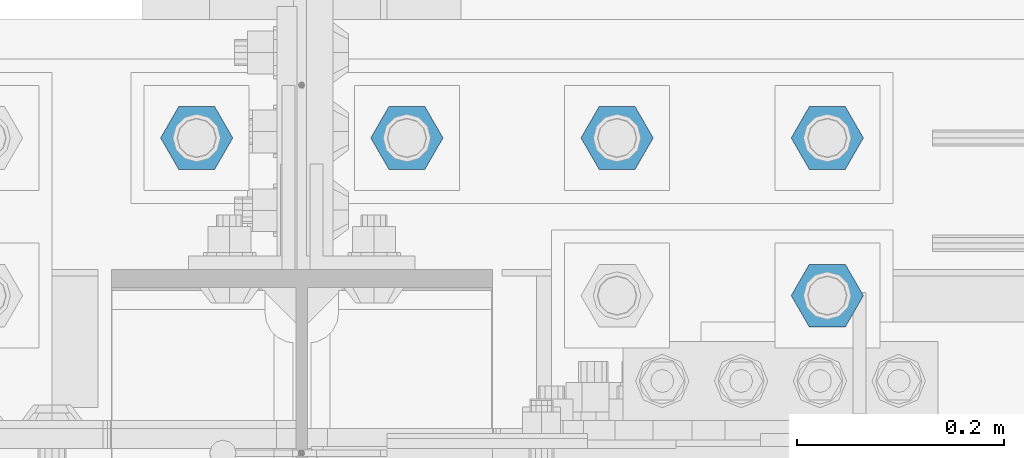
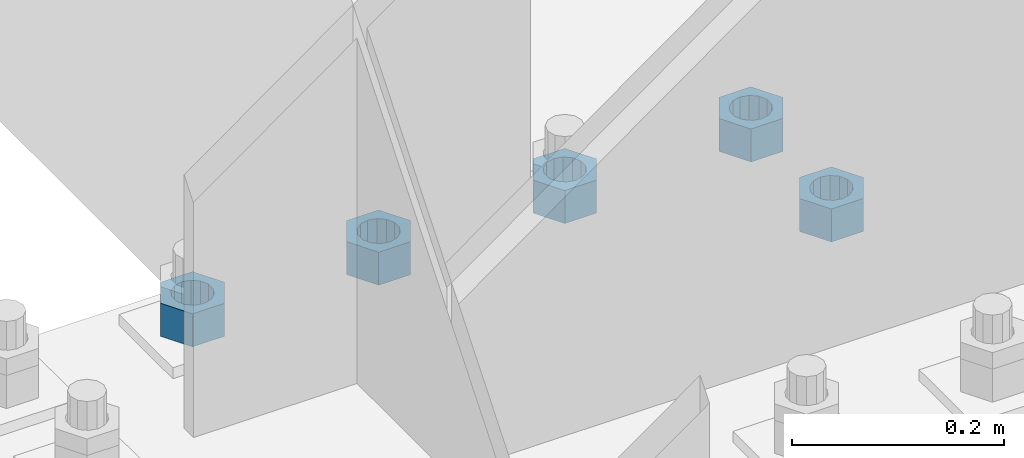
# One storey, part 1654 of 3843: 5 columns, 1 element without a shape of its own.
"""IFC2X3 building model written with IfcOpenShell, lengths in millimetres."""

from ifc_helpers import new_model, si_unit, frame, origin_with_axes, place, context, subcontext, project, spatial, faceted_brep, material, type_object, element, aggregate, save


model = new_model("IFC2X3")

# Units and contexts
model_context = context("Model", 3, precision=1e-05, world=origin_with_axes())
body_context = subcontext(model_context, "Body", "Model", "MODEL_VIEW")
ifc_project = project(units=[si_unit("LENGTHUNIT", "METRE", prefix="MILLI"), si_unit("AREAUNIT", "SQUARE_METRE"), si_unit("VOLUMEUNIT", "CUBIC_METRE"), si_unit("MASSUNIT", "GRAM", prefix="KILO"), si_unit("TIMEUNIT", "SECOND"), si_unit("PLANEANGLEUNIT", "RADIAN"), si_unit("SOLIDANGLEUNIT", "STERADIAN"), si_unit("THERMODYNAMICTEMPERATUREUNIT", "DEGREE_CELSIUS"), si_unit("LUMINOUSINTENSITYUNIT", "LUMEN")], contexts=[model_context])

# Site, building, storey
site_placement = place(None, origin_with_axes())
site = spatial("IfcSite", under=ifc_project, at=site_placement, CompositionType="ELEMENT")
building_placement = place(site_placement, origin_with_axes())
building = spatial("IfcBuilding", under=site, at=building_placement, Name="Undefined", CompositionType="ELEMENT")
storey_placement = place(building_placement, origin_with_axes())
storey = spatial("IfcBuildingStorey", under=building, at=storey_placement, Name="Undefined", CompositionType="ELEMENT", Elevation=0.0)

# Assembly, columns
assembly_placement = place(storey_placement, origin_with_axes())
assembly = element("IfcElementAssembly", 1, at=assembly_placement, inside=storey, Name="TEMPLATE", AssemblyPlace="NOTDEFINED", PredefinedType="RIGID_FRAME")
ifc_material = material(Name="STEEL/A572-50")
column_type = type_object("IfcColumnType", Name="1-1/2_HEAVY_HEX_NUT", PredefinedType="NOTDEFINED")
column_1_placement = place(assembly_placement, frame((42570.4, 25768.3, 29730.7), z_axis=(0.0, 1.0, 0.0), x_axis=(0.0, 0.0, -1.0)))
column_1 = element("IfcColumn", 2, at=column_1_placement, type_object=column_type, material=ifc_material, Name="NUT", ObjectType="1-1/2_HEAVY_HEX_NUT", context=body_context, shape_type="Brep", body=[
    faceted_brep([(0.0, -34.9199981689453, 0.0), (0.0, -17.4599990844727, -30.25), (38.0999999999985, -17.4599990844727, -30.25), (38.0999999999985, -34.9199981689453, 0.0), (0.0, 17.4599990844727, -30.25), (38.0999999999985, 17.4599990844727, -30.25), (0.0, 34.9199981689453, 0.0), (38.0999999999985, 34.9199981689453, 0.0), (0.0, 17.4599990844727, 30.25), (38.0999999999985, 17.4599990844727, 30.25), (0.0, -17.4599990844727, 30.25), (38.0999999999985, -17.4599990844727, 30.25), (0.0, 0.0, 20.6399993896484), (0.0, 8.9553601105581, 18.5959968835959), (38.0999999999985, 8.9553601105581, 18.5959968835959), (38.0999999999985, 0.0, 20.6399993896484), (0.0, 16.1370013209525, 12.8688291298167), (38.0999999999985, 16.1370013209525, 12.8688291298167), (0.0, 20.1225115123816, 4.59283194104501), (38.0999999999985, 20.1225115123816, 4.59283194104501), (0.0, 20.1225115123816, -4.59283194104501), (38.0999999999985, 20.1225115123816, -4.59283194104501), (0.0, 16.1370013209525, -12.8688291298167), (38.0999999999985, 16.1370013209525, -12.8688291298167), (0.0, 8.9553601105581, -18.5959968835959), (38.0999999999985, 8.9553601105581, -18.5959968835959), (0.0, 0.0, -20.6399993896484), (38.0999999999985, 0.0, -20.6399993896484), (0.0, -8.9553601105581, -18.5959968835959), (38.0999999999985, -8.9553601105581, -18.5959968835959), (0.0, -16.1370013209525, -12.8688291298167), (38.0999999999985, -16.1370013209525, -12.8688291298167), (0.0, -20.1225115123816, -4.59283194104501), (38.0999999999985, -20.1225115123816, -4.59283194104501), (0.0, -20.1225115123816, 4.59283194104501), (38.0999999999985, -20.1225115123816, 4.59283194104501), (0.0, -16.1370013209525, 12.8688291298167), (38.0999999999985, -16.1370013209525, 12.8688291298167), (0.0, -8.9553601105581, 18.5959968835959), (38.0999999999985, -8.9553601105581, 18.5959968835959)], [[[0, 1, 2, 3]], [[1, 4, 5, 2]], [[4, 6, 7, 5]], [[6, 8, 9, 7]], [[8, 10, 11, 9]], [[10, 0, 3, 11]], [[12, 13, 14, 15]], [[13, 16, 17, 14]], [[16, 18, 19, 17]], [[18, 20, 21, 19]], [[20, 22, 23, 21]], [[22, 24, 25, 23]], [[24, 26, 27, 25]], [[26, 28, 29, 27]], [[28, 30, 31, 29]], [[30, 32, 33, 31]], [[32, 34, 35, 33]], [[34, 36, 37, 35]], [[36, 38, 39, 37]], [[38, 12, 15, 39]], [[5, 7, 9, 11, 3, 2], [17, 19, 21, 23, 25, 27, 29, 31, 33, 35, 37, 39, 15, 14]], [[10, 8, 6, 4, 1, 0], [38, 36, 34, 32, 30, 28, 26, 24, 22, 20, 18, 16, 13, 12]]]),
])
column_2_placement = place(assembly_placement, frame((41960.8, 25920.7, 29730.7), z_axis=(0.0, -1.0, 0.0), x_axis=(0.0, 0.0, -1.0)))
column_2 = element("IfcColumn", 3, at=column_2_placement, type_object=column_type, material=ifc_material, Name="NUT", ObjectType="1-1/2_HEAVY_HEX_NUT", context=body_context, shape_type="Brep", body=[
    faceted_brep([(0.0, -34.9199981689453, 0.0), (0.0, -17.4599990844727, -30.25), (38.0999999999985, -17.4599990844727, -30.25), (38.0999999999985, -34.9199981689453, 0.0), (0.0, 17.4599990844727, -30.25), (38.0999999999985, 17.4599990844727, -30.25), (0.0, 34.9199981689453, 0.0), (38.0999999999985, 34.9199981689453, 0.0), (0.0, 17.4599990844727, 30.25), (38.0999999999985, 17.4599990844727, 30.25), (0.0, -17.4599990844727, 30.25), (38.0999999999985, -17.4599990844727, 30.25), (0.0, 0.0, 20.6399993896484), (0.0, 8.9553601105581, 18.5959968835959), (38.0999999999985, 8.9553601105581, 18.5959968835959), (38.0999999999985, 0.0, 20.6399993896484), (0.0, 16.1370013209525, 12.8688291298167), (38.0999999999985, 16.1370013209525, 12.8688291298167), (0.0, 20.1225115123816, 4.59283194104501), (38.0999999999985, 20.1225115123816, 4.59283194104501), (0.0, 20.1225115123816, -4.59283194104501), (38.0999999999985, 20.1225115123816, -4.59283194104501), (0.0, 16.1370013209525, -12.8688291298167), (38.0999999999985, 16.1370013209525, -12.8688291298167), (0.0, 8.9553601105581, -18.5959968835959), (38.0999999999985, 8.9553601105581, -18.5959968835959), (0.0, 0.0, -20.6399993896484), (38.0999999999985, 0.0, -20.6399993896484), (0.0, -8.9553601105581, -18.5959968835959), (38.0999999999985, -8.9553601105581, -18.5959968835959), (0.0, -16.1370013209525, -12.8688291298167), (38.0999999999985, -16.1370013209525, -12.8688291298167), (0.0, -20.1225115123816, -4.59283194104501), (38.0999999999985, -20.1225115123816, -4.59283194104501), (0.0, -20.1225115123816, 4.59283194104501), (38.0999999999985, -20.1225115123816, 4.59283194104501), (0.0, -16.1370013209525, 12.8688291298167), (38.0999999999985, -16.1370013209525, 12.8688291298167), (0.0, -8.9553601105581, 18.5959968835959), (38.0999999999985, -8.9553601105581, 18.5959968835959)], [[[0, 1, 2, 3]], [[1, 4, 5, 2]], [[4, 6, 7, 5]], [[6, 8, 9, 7]], [[8, 10, 11, 9]], [[10, 0, 3, 11]], [[12, 13, 14, 15]], [[13, 16, 17, 14]], [[16, 18, 19, 17]], [[18, 20, 21, 19]], [[20, 22, 23, 21]], [[22, 24, 25, 23]], [[24, 26, 27, 25]], [[26, 28, 29, 27]], [[28, 30, 31, 29]], [[30, 32, 33, 31]], [[32, 34, 35, 33]], [[34, 36, 37, 35]], [[36, 38, 39, 37]], [[38, 12, 15, 39]], [[5, 7, 9, 11, 3, 2], [17, 19, 21, 23, 25, 27, 29, 31, 33, 35, 37, 39, 15, 14]], [[10, 8, 6, 4, 1, 0], [38, 36, 34, 32, 30, 28, 26, 24, 22, 20, 18, 16, 13, 12]]]),
])
column_3_placement = place(assembly_placement, frame((42164.0, 25920.7, 29730.7), z_axis=(0.0, -1.0, 0.0), x_axis=(0.0, 0.0, -1.0)))
column_3 = element("IfcColumn", 4, at=column_3_placement, type_object=column_type, material=ifc_material, Name="NUT", ObjectType="1-1/2_HEAVY_HEX_NUT", context=body_context, shape_type="Brep", body=[
    faceted_brep([(0.0, -34.9199981689453, 0.0), (0.0, -17.4599990844727, -30.25), (38.0999999999985, -17.4599990844727, -30.25), (38.0999999999985, -34.9199981689453, 0.0), (0.0, 17.4599990844727, -30.25), (38.0999999999985, 17.4599990844727, -30.25), (0.0, 34.9199981689453, 0.0), (38.0999999999985, 34.9199981689453, 0.0), (0.0, 17.4599990844727, 30.25), (38.0999999999985, 17.4599990844727, 30.25), (0.0, -17.4599990844727, 30.25), (38.0999999999985, -17.4599990844727, 30.25), (0.0, 0.0, 20.6399993896484), (0.0, 8.9553601105581, 18.5959968835959), (38.0999999999985, 8.9553601105581, 18.5959968835959), (38.0999999999985, 0.0, 20.6399993896484), (0.0, 16.1370013209525, 12.8688291298167), (38.0999999999985, 16.1370013209525, 12.8688291298167), (0.0, 20.1225115123816, 4.59283194104501), (38.0999999999985, 20.1225115123816, 4.59283194104501), (0.0, 20.1225115123816, -4.59283194104501), (38.0999999999985, 20.1225115123816, -4.59283194104501), (0.0, 16.1370013209525, -12.8688291298167), (38.0999999999985, 16.1370013209525, -12.8688291298167), (0.0, 8.9553601105581, -18.5959968835959), (38.0999999999985, 8.9553601105581, -18.5959968835959), (0.0, 0.0, -20.6399993896484), (38.0999999999985, 0.0, -20.6399993896484), (0.0, -8.9553601105581, -18.5959968835959), (38.0999999999985, -8.9553601105581, -18.5959968835959), (0.0, -16.1370013209525, -12.8688291298167), (38.0999999999985, -16.1370013209525, -12.8688291298167), (0.0, -20.1225115123816, -4.59283194104501), (38.0999999999985, -20.1225115123816, -4.59283194104501), (0.0, -20.1225115123816, 4.59283194104501), (38.0999999999985, -20.1225115123816, 4.59283194104501), (0.0, -16.1370013209525, 12.8688291298167), (38.0999999999985, -16.1370013209525, 12.8688291298167), (0.0, -8.9553601105581, 18.5959968835959), (38.0999999999985, -8.9553601105581, 18.5959968835959)], [[[0, 1, 2, 3]], [[1, 4, 5, 2]], [[4, 6, 7, 5]], [[6, 8, 9, 7]], [[8, 10, 11, 9]], [[10, 0, 3, 11]], [[12, 13, 14, 15]], [[13, 16, 17, 14]], [[16, 18, 19, 17]], [[18, 20, 21, 19]], [[20, 22, 23, 21]], [[22, 24, 25, 23]], [[24, 26, 27, 25]], [[26, 28, 29, 27]], [[28, 30, 31, 29]], [[30, 32, 33, 31]], [[32, 34, 35, 33]], [[34, 36, 37, 35]], [[36, 38, 39, 37]], [[38, 12, 15, 39]], [[5, 7, 9, 11, 3, 2], [17, 19, 21, 23, 25, 27, 29, 31, 33, 35, 37, 39, 15, 14]], [[10, 8, 6, 4, 1, 0], [38, 36, 34, 32, 30, 28, 26, 24, 22, 20, 18, 16, 13, 12]]]),
])
column_4_placement = place(assembly_placement, frame((42367.2, 25920.7, 29730.7), z_axis=(0.0, 1.0, 0.0), x_axis=(0.0, 0.0, -1.0)))
column_4 = element("IfcColumn", 5, at=column_4_placement, type_object=column_type, material=ifc_material, Name="NUT", ObjectType="1-1/2_HEAVY_HEX_NUT", context=body_context, shape_type="Brep", body=[
    faceted_brep([(0.0, -34.9199981689453, 0.0), (0.0, -17.4599990844727, -30.25), (38.0999999999985, -17.4599990844727, -30.25), (38.0999999999985, -34.9199981689453, 0.0), (0.0, 17.4599990844727, -30.25), (38.0999999999985, 17.4599990844727, -30.25), (0.0, 34.9199981689453, 0.0), (38.0999999999985, 34.9199981689453, 0.0), (0.0, 17.4599990844727, 30.25), (38.0999999999985, 17.4599990844727, 30.25), (0.0, -17.4599990844727, 30.25), (38.0999999999985, -17.4599990844727, 30.25), (0.0, 0.0, 20.6399993896484), (0.0, 8.9553601105581, 18.5959968835959), (38.0999999999985, 8.9553601105581, 18.5959968835959), (38.0999999999985, 0.0, 20.6399993896484), (0.0, 16.1370013209525, 12.8688291298167), (38.0999999999985, 16.1370013209525, 12.8688291298167), (0.0, 20.1225115123816, 4.59283194104501), (38.0999999999985, 20.1225115123816, 4.59283194104501), (0.0, 20.1225115123816, -4.59283194104501), (38.0999999999985, 20.1225115123816, -4.59283194104501), (0.0, 16.1370013209525, -12.8688291298167), (38.0999999999985, 16.1370013209525, -12.8688291298167), (0.0, 8.9553601105581, -18.5959968835959), (38.0999999999985, 8.9553601105581, -18.5959968835959), (0.0, 0.0, -20.6399993896484), (38.0999999999985, 0.0, -20.6399993896484), (0.0, -8.9553601105581, -18.5959968835959), (38.0999999999985, -8.9553601105581, -18.5959968835959), (0.0, -16.1370013209525, -12.8688291298167), (38.0999999999985, -16.1370013209525, -12.8688291298167), (0.0, -20.1225115123816, -4.59283194104501), (38.0999999999985, -20.1225115123816, -4.59283194104501), (0.0, -20.1225115123816, 4.59283194104501), (38.0999999999985, -20.1225115123816, 4.59283194104501), (0.0, -16.1370013209525, 12.8688291298167), (38.0999999999985, -16.1370013209525, 12.8688291298167), (0.0, -8.9553601105581, 18.5959968835959), (38.0999999999985, -8.9553601105581, 18.5959968835959)], [[[0, 1, 2, 3]], [[1, 4, 5, 2]], [[4, 6, 7, 5]], [[6, 8, 9, 7]], [[8, 10, 11, 9]], [[10, 0, 3, 11]], [[12, 13, 14, 15]], [[13, 16, 17, 14]], [[16, 18, 19, 17]], [[18, 20, 21, 19]], [[20, 22, 23, 21]], [[22, 24, 25, 23]], [[24, 26, 27, 25]], [[26, 28, 29, 27]], [[28, 30, 31, 29]], [[30, 32, 33, 31]], [[32, 34, 35, 33]], [[34, 36, 37, 35]], [[36, 38, 39, 37]], [[38, 12, 15, 39]], [[5, 7, 9, 11, 3, 2], [17, 19, 21, 23, 25, 27, 29, 31, 33, 35, 37, 39, 15, 14]], [[10, 8, 6, 4, 1, 0], [38, 36, 34, 32, 30, 28, 26, 24, 22, 20, 18, 16, 13, 12]]]),
])
column_5_placement = place(assembly_placement, frame((42570.4, 25920.7, 29730.7), z_axis=(0.0, 1.0, 0.0), x_axis=(0.0, 0.0, -1.0)))
column_5 = element("IfcColumn", 6, at=column_5_placement, type_object=column_type, material=ifc_material, Name="NUT", ObjectType="1-1/2_HEAVY_HEX_NUT", context=body_context, shape_type="Brep", body=[
    faceted_brep([(0.0, -34.9199981689453, 0.0), (0.0, -17.4599990844727, -30.25), (38.0999999999985, -17.4599990844727, -30.25), (38.0999999999985, -34.9199981689453, 0.0), (0.0, 17.4599990844727, -30.25), (38.0999999999985, 17.4599990844727, -30.25), (0.0, 34.9199981689453, 0.0), (38.0999999999985, 34.9199981689453, 0.0), (0.0, 17.4599990844727, 30.25), (38.0999999999985, 17.4599990844727, 30.25), (0.0, -17.4599990844727, 30.25), (38.0999999999985, -17.4599990844727, 30.25), (0.0, 0.0, 20.6399993896484), (0.0, 8.9553601105581, 18.5959968835959), (38.0999999999985, 8.9553601105581, 18.5959968835959), (38.0999999999985, 0.0, 20.6399993896484), (0.0, 16.1370013209525, 12.8688291298167), (38.0999999999985, 16.1370013209525, 12.8688291298167), (0.0, 20.1225115123816, 4.59283194104501), (38.0999999999985, 20.1225115123816, 4.59283194104501), (0.0, 20.1225115123816, -4.59283194104501), (38.0999999999985, 20.1225115123816, -4.59283194104501), (0.0, 16.1370013209525, -12.8688291298167), (38.0999999999985, 16.1370013209525, -12.8688291298167), (0.0, 8.9553601105581, -18.5959968835959), (38.0999999999985, 8.9553601105581, -18.5959968835959), (0.0, 0.0, -20.6399993896484), (38.0999999999985, 0.0, -20.6399993896484), (0.0, -8.9553601105581, -18.5959968835959), (38.0999999999985, -8.9553601105581, -18.5959968835959), (0.0, -16.1370013209525, -12.8688291298167), (38.0999999999985, -16.1370013209525, -12.8688291298167), (0.0, -20.1225115123816, -4.59283194104501), (38.0999999999985, -20.1225115123816, -4.59283194104501), (0.0, -20.1225115123816, 4.59283194104501), (38.0999999999985, -20.1225115123816, 4.59283194104501), (0.0, -16.1370013209525, 12.8688291298167), (38.0999999999985, -16.1370013209525, 12.8688291298167), (0.0, -8.9553601105581, 18.5959968835959), (38.0999999999985, -8.9553601105581, 18.5959968835959)], [[[0, 1, 2, 3]], [[1, 4, 5, 2]], [[4, 6, 7, 5]], [[6, 8, 9, 7]], [[8, 10, 11, 9]], [[10, 0, 3, 11]], [[12, 13, 14, 15]], [[13, 16, 17, 14]], [[16, 18, 19, 17]], [[18, 20, 21, 19]], [[20, 22, 23, 21]], [[22, 24, 25, 23]], [[24, 26, 27, 25]], [[26, 28, 29, 27]], [[28, 30, 31, 29]], [[30, 32, 33, 31]], [[32, 34, 35, 33]], [[34, 36, 37, 35]], [[36, 38, 39, 37]], [[38, 12, 15, 39]], [[5, 7, 9, 11, 3, 2], [17, 19, 21, 23, 25, 27, 29, 31, 33, 35, 37, 39, 15, 14]], [[10, 8, 6, 4, 1, 0], [38, 36, 34, 32, 30, 28, 26, 24, 22, 20, 18, 16, 13, 12]]]),
])
aggregate(assembly, [column_1, column_2, column_3, column_4, column_5])

save(model, "model.ifc")
